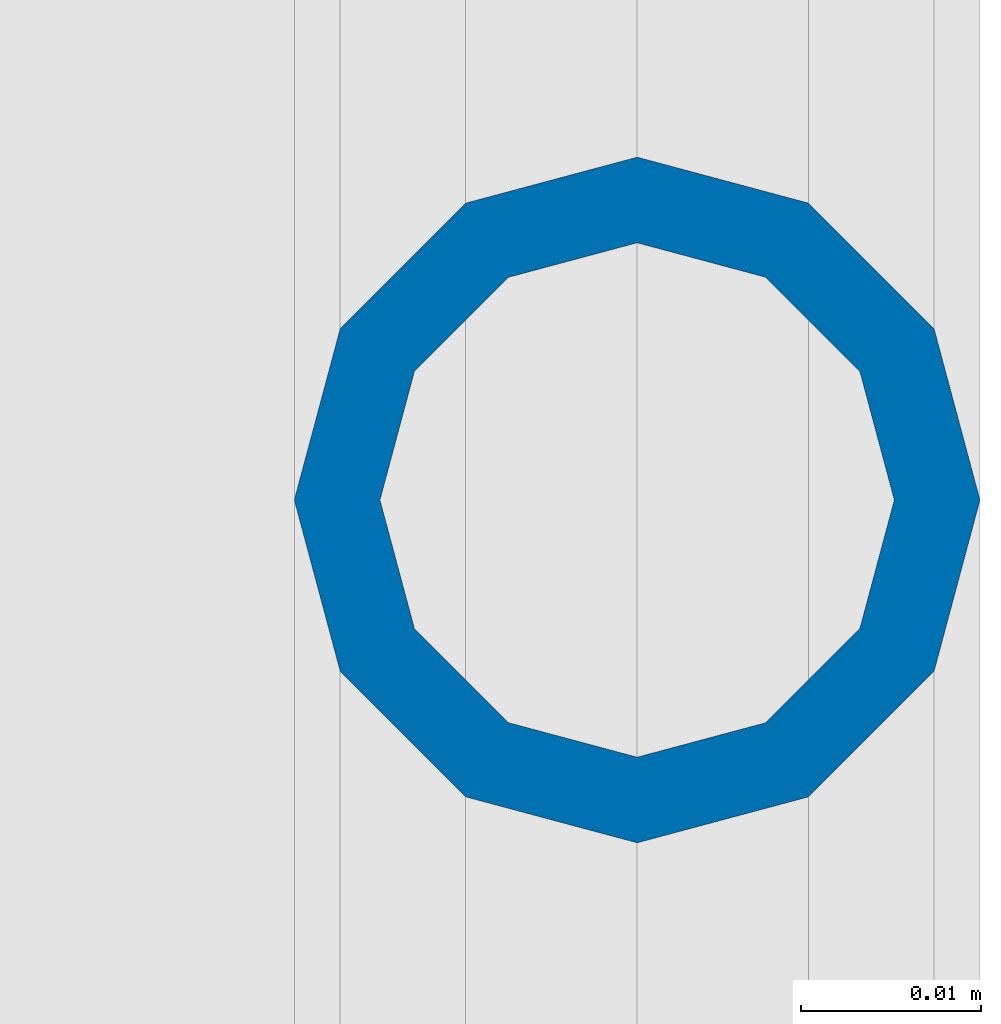
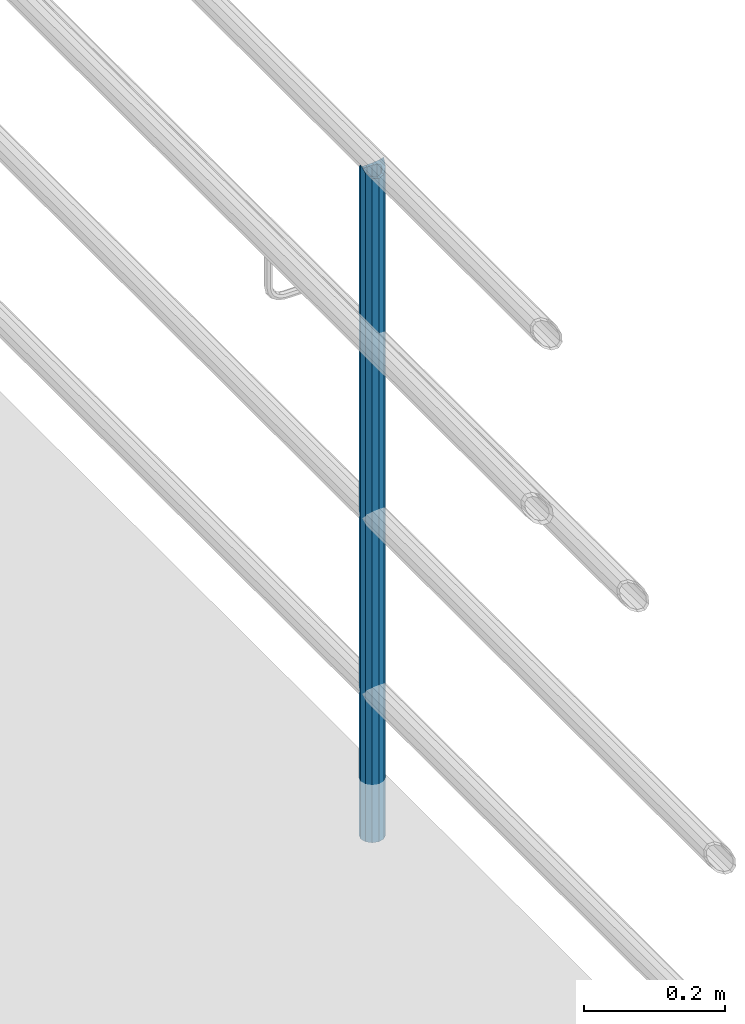
# One storey, part 671 of 1876: 1 column, 1 element without a shape of its own.
"""IFC2X3 building model written with IfcOpenShell, lengths in millimetres."""

from ifc_helpers import new_model, si_unit, frame, origin_with_axes, place, context, subcontext, project, spatial, faceted_brep, material, type_object, element, aggregate, save


model = new_model("IFC2X3")

# Units and contexts
model_context = context("Model", 3, precision=1e-05, world=origin_with_axes())
body_context = subcontext(model_context, "Body", "Model", "MODEL_VIEW")
ifc_project = project(units=[si_unit("LENGTHUNIT", "METRE", prefix="MILLI"), si_unit("AREAUNIT", "SQUARE_METRE"), si_unit("VOLUMEUNIT", "CUBIC_METRE"), si_unit("MASSUNIT", "GRAM", prefix="KILO"), si_unit("TIMEUNIT", "SECOND"), si_unit("PLANEANGLEUNIT", "RADIAN"), si_unit("SOLIDANGLEUNIT", "STERADIAN"), si_unit("THERMODYNAMICTEMPERATUREUNIT", "DEGREE_CELSIUS"), si_unit("LUMINOUSINTENSITYUNIT", "LUMEN")], contexts=[model_context])

# Site, building, storey
site_placement = place(None, origin_with_axes())
site = spatial("IfcSite", under=ifc_project, at=site_placement, CompositionType="ELEMENT")
building_placement = place(site_placement, origin_with_axes())
building = spatial("IfcBuilding", under=site, at=building_placement, Name="Undefined", CompositionType="ELEMENT")
storey_placement = place(building_placement, origin_with_axes())
storey = spatial("IfcBuildingStorey", under=building, at=storey_placement, Name="Undefined", CompositionType="ELEMENT", Elevation=0.0)

# Assembly, column
assembly_placement = place(storey_placement, origin_with_axes())
assembly = element("IfcElementAssembly", 1, at=assembly_placement, inside=storey, Name="RAIL", AssemblyPlace="NOTDEFINED", PredefinedType="RIGID_FRAME")
ifc_material = material()
column_type = type_object("IfcColumnType", PredefinedType="NOTDEFINED")
column_placement = place(assembly_placement, frame((9556.7501953125, -3810.00009765727, 76.2000030526367), z_axis=(0.0, 1.0, 0.0), x_axis=(0.0, 0.0, 1.0)))
column = element("IfcColumn", 2, at=column_placement, type_object=column_type, material=ifc_material, Name="POST", context=body_context, shape_type="Brep", body=[
    faceted_brep([(1151.90221606134, -9.52499999999964, 16.4977839420935), (1151.90221606134, -9.52499999999964, 9.99208795657023), (1151.26416204686, -7.14374999999927, 12.3733379565701), (1149.35000000343, 0.0, 14.2874999999999), (1149.35000000343, 0.0, 19.0500000000002), (1151.26416204686, 7.14374999999927, 12.3733379565701), (1151.90221606134, 9.52499999999964, 9.99208795657023), (1151.90221606134, 9.52499999999964, 16.4977839420935), (1168.40000000408, 19.0499999999993, 0.0), (1158.87500000343, 16.4977839420935, 9.52500000000009), (1158.87500000408, 16.4977839420935, -9.52500000000009), (1154.75055401791, 12.373337956571, 7.14375000000018), (1156.66471606134, 14.2875000000004, 0.0), (1154.75055401791, 12.373337956571, -7.14375000000018), (1151.90221606134, 9.52499999999964, -9.99208795657023), (1151.90221606199, 9.52499999999964, -16.4977839420935), (1151.26416204686, 7.14374999999927, -12.3733379565701), (1149.35000000343, 0.0, -14.2874999999999), (1149.35000000408, 0.0, -19.0500000000002), (1151.90221606134, -9.52499999999964, -9.99208795657023), (1151.90221606199, -9.52499999999964, -16.4977839420935), (1151.26416204686, -7.14374999999927, -12.3733379565701), (1168.40000000408, -19.0499999999993, 0.0), (1158.87500000408, -16.4977839420935, -9.52500000000009), (1158.87500000343, -16.4977839420935, 9.52500000000009), (1154.75055401791, -12.373337956571, -7.14375000000018), (1156.66471606134, -14.2875000000004, 0.0), (1154.75055401791, -12.373337956571, 7.14375000000018), (0.0, -16.4977839420935, -9.52500000000146), (0.0, -9.52500000000009, -16.4977839420935), (0.0, 0.0, -19.05), (0.0, 9.52500000000009, -16.4977839420935), (0.0, 16.4977839420935, -9.52500000000146), (-9.09494701772928e-13, 19.05, -1.81898940354586e-12), (0.0, 16.4977839420935, 9.52500000000146), (0.0, 9.52500000000009, 16.4977839420935), (0.0, 0.0, 19.0499999999993), (0.0, -9.52500000000009, 16.4977839420935), (0.0, -16.4977839420935, 9.52500000000146), (0.0, -19.0500000000002, 0.0), (0.0, -12.373337956571, -7.14375000000018), (0.0, -7.14374999999927, -12.3733379565701), (0.0, 0.0, -14.2874999999999), (0.0, 7.14374999999927, -12.3733379565701), (0.0, 12.373337956571, -7.14375000000018), (0.0, 14.2875000000004, 0.0), (0.0, 12.373337956571, 7.14375000000018), (0.0, 7.14374999999927, 12.3733379565701), (0.0, 0.0, 14.2874999999999), (0.0, -7.14374999999927, 12.3733379565701), (0.0, -12.373337956571, 7.14375000000018), (0.0, -14.2875000000004, 0.0)], [[[0, 1, 2, 3, 4]], [[4, 3, 5, 6, 7]], [[8, 9, 10]], [[7, 6, 11, 12, 13, 14, 15, 10, 9]], [[16, 17, 18, 15, 14]], [[19, 20, 18, 17, 21]], [[22, 23, 24]], [[24, 23, 20, 19, 25, 26, 27, 1, 0]], [[28, 29, 20, 23]], [[29, 30, 18, 20]], [[30, 31, 15, 18]], [[31, 32, 10, 15]], [[32, 33, 8, 10]], [[33, 34, 9, 8]], [[34, 35, 7, 9]], [[35, 36, 4, 7]], [[36, 37, 0, 4]], [[37, 38, 24, 0]], [[38, 39, 22, 24]], [[39, 28, 23, 22]], [[38, 37, 36, 35, 34, 33, 32, 31, 30, 29, 28, 39], [40, 41, 42, 43, 44, 45, 46, 47, 48, 49, 50, 51]], [[40, 51, 26, 25]], [[21, 41, 40, 25, 19]], [[42, 41, 21, 17]], [[43, 42, 17, 16]], [[44, 43, 16, 14, 13]], [[45, 44, 13, 12]], [[46, 45, 12, 11]], [[5, 47, 46, 11, 6]], [[48, 47, 5, 3]], [[49, 48, 3, 2]], [[50, 49, 2, 1, 27]], [[51, 50, 27, 26]]]),
])
aggregate(assembly, [column])

save(model, "model.ifc")
